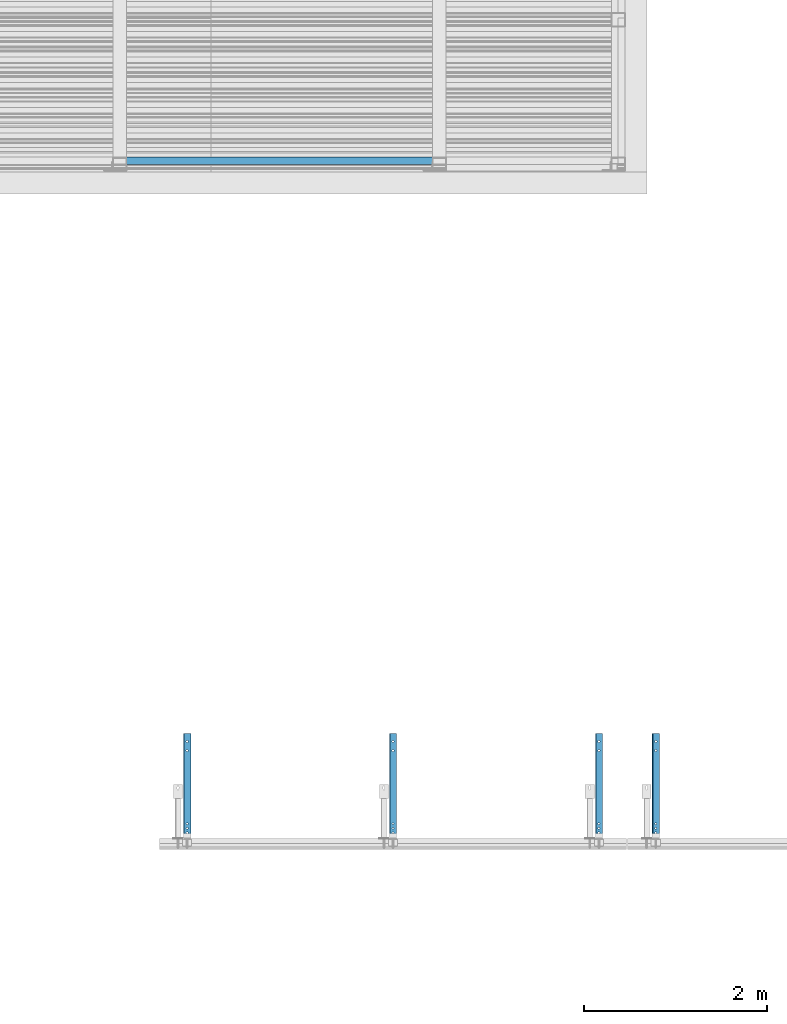
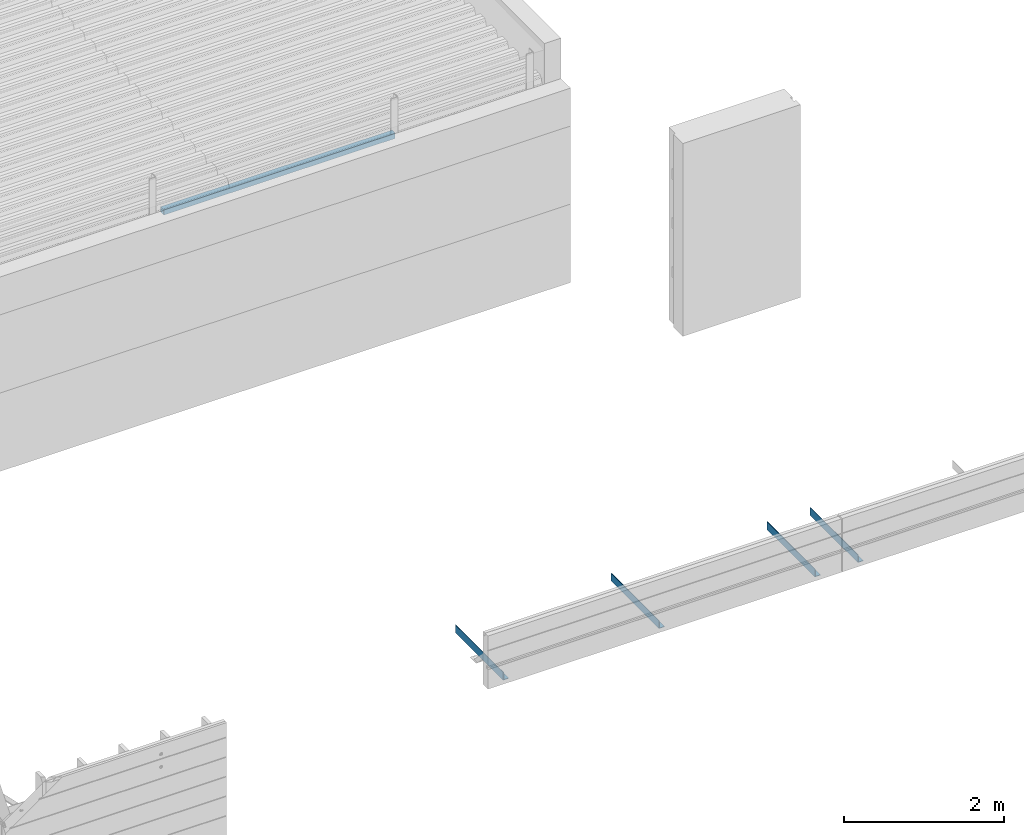
# One storey, part 20 of 153: 5 beams, 5 elements without a shape of their own.
"""IFC2X3 building model written with IfcOpenShell, lengths in millimetres."""

from ifc_helpers import new_model, si_unit, frame, origin_with_axes, place, context, subcontext, project, spatial, faceted_brep, material, type_object, element, aggregate, save


model = new_model("IFC2X3")

# Units and contexts
model_context = context("Model", 3, precision=1e-05, world=origin_with_axes())
body_context = subcontext(model_context, "Body", "Model", "MODEL_VIEW")
ifc_project = project(units=[si_unit("LENGTHUNIT", "METRE", prefix="MILLI"), si_unit("AREAUNIT", "SQUARE_METRE"), si_unit("VOLUMEUNIT", "CUBIC_METRE"), si_unit("MASSUNIT", "GRAM", prefix="KILO"), si_unit("TIMEUNIT", "SECOND"), si_unit("PLANEANGLEUNIT", "RADIAN"), si_unit("SOLIDANGLEUNIT", "STERADIAN"), si_unit("THERMODYNAMICTEMPERATUREUNIT", "DEGREE_CELSIUS"), si_unit("LUMINOUSINTENSITYUNIT", "LUMEN")], contexts=[model_context])

# Site, building, storey
site_placement = place(None, origin_with_axes())
site = spatial("IfcSite", under=ifc_project, at=site_placement, CompositionType="ELEMENT")
building_placement = place(site_placement, origin_with_axes())
building = spatial("IfcBuilding", under=site, at=building_placement, CompositionType="ELEMENT")
storey_placement = place(building_placement, origin_with_axes())
storey = spatial("IfcBuildingStorey", under=building, at=storey_placement, Name="8", CompositionType="ELEMENT", Elevation=0.0)

# Assembly, beam
assembly_1_placement = place(storey_placement, origin_with_axes())
assembly_1 = element("IfcElementAssembly", 1, at=assembly_1_placement, inside=storey, Name="Steel Assembly", AssemblyPlace="NOTDEFINED", PredefinedType="RIGID_FRAME")
ifc_material_1 = material(Name="STEEL/S355J2")
beam_type_1 = type_object("IfcBeamType", Name="80X80X4", PredefinedType="NOTDEFINED")
beam_1_placement = place(assembly_1_placement, frame((16327.0, 15090.0, 105625.0), z_axis=(0.0, 0.0, 1.0), x_axis=(1.0, 0.0, 0.0)))
beam_1 = element("IfcBeam", 2, at=beam_1_placement, type_object=beam_type_1, material=ifc_material_1, ObjectType="80X80X4", context=body_context, shape_type="Brep", body=[
    faceted_brep([(0.0, 36.0, -36.0), (0.0, -36.0, -36.0), (3350.0, -36.0, -36.0), (3350.0, 36.0, -36.0), (0.0, -36.0, 36.0), (3350.0, -36.0, 36.0), (0.0, 36.0, 36.0), (3350.0, 36.0, 36.0), (0.0, 40.0, -40.0), (0.0, 40.0, 40.0), (3350.0, 40.0, 40.0), (3350.0, 40.0, -40.0), (0.0, -40.0, 40.0), (3350.0, -40.0, 40.0), (0.0, -40.0, -40.0), (3350.0, -40.0, -40.0)], [[[0, 1, 2, 3]], [[1, 4, 5, 2]], [[4, 6, 7, 5]], [[6, 0, 3, 7]], [[8, 9, 10, 11]], [[9, 12, 13, 10]], [[12, 14, 15, 13]], [[14, 8, 11, 15]], [[13, 15, 11, 10], [5, 7, 3, 2]], [[14, 12, 9, 8], [6, 4, 1, 0]]]),
])
aggregate(assembly_1, [beam_1])

assembly_2_placement = place(storey_placement, origin_with_axes())
assembly_2 = element("IfcElementAssembly", 3, at=assembly_2_placement, inside=storey, Name="Steel Assembly", AssemblyPlace="NOTDEFINED", PredefinedType="RIGID_FRAME")
ifc_material_2 = material(Name="STEEL/S235J2")
beam_type_2 = type_object("IfcBeamType", PredefinedType="NOTDEFINED")
beam_2_placement = place(assembly_2_placement, frame((16990.0, 7620.0, 102815.0), z_axis=(0.0, 0.0, 1.0), x_axis=(0.0, 1.0, 0.0)))
beam_2 = element("IfcBeam", 4, at=beam_2_placement, type_object=beam_type_2, material=ifc_material_2, context=body_context, shape_type="Brep", body=[
    faceted_brep([(152.928932188135, -7.07106781186485, -52.0), (152.928932188135, -7.07106781186485, -60.0), (150.0, 0.0, -60.0), (150.0, 0.0, -52.0), (152.928932188135, 7.07106781186485, -60.0), (152.928932188135, 7.07106781186485, -52.0), (160.0, 10.0, -60.0), (160.0, 10.0, -52.0), (167.071067811865, 7.07106781186485, -60.0), (167.071067811865, 7.07106781186485, -52.0), (170.0, 0.0, -60.0), (170.0, 0.0, -52.0), (167.071067811865, -7.07106781186485, -60.0), (167.071067811865, -7.07106781186485, -52.0), (160.0, -10.0, -60.0), (160.0, -10.0, -52.0), (0.0, -40.0, -52.0), (0.0, -40.0, -60.0), (1200.0, -40.0, -60.0), (1200.0, -40.0, -52.0), (0.0, 32.0, -52.0), (0.0, 32.0, 60.0), (0.0, 40.0, 60.0), (0.0, 40.0, -60.0), (1200.0, 32.0, -52.0), (1200.0, 32.0, 60.0), (1200.0, 40.0, 60.0), (1200.0, 40.0, -60.0), (1115.75, -9.95929214352145, -52.0), (1115.75, -9.95929214352145, -60.0), (1110.0, -11.5, -60.0), (1110.0, -11.5, -52.0), (1119.95929214352, -5.75, -52.0), (1119.95929214352, -5.75, -60.0), (1121.5, 0.0, -52.0), (1121.5, 0.0, -60.0), (1119.95929214352, 5.75, -52.0), (1119.95929214352, 5.75, -60.0), (1115.75, 9.95929214352145, -52.0), (1115.75, 9.95929214352145, -60.0), (1110.0, 11.5, -52.0), (1110.0, 11.5, -60.0), (1104.25, 9.95929214352145, -52.0), (1104.25, 9.95929214352145, -60.0), (1100.04070785648, 5.75, -52.0), (1100.04070785648, 5.75, -60.0), (1098.5, 0.0, -52.0), (1098.5, 0.0, -60.0), (1100.04070785648, -5.75, -52.0), (1100.04070785648, -5.75, -60.0), (1104.25, -9.95929214352145, -52.0), (1104.25, -9.95929214352145, -60.0), (1015.75, -9.95929214352145, -52.0), (1015.75, -9.95929214352145, -60.0), (1010.0, -11.5, -60.0), (1010.0, -11.5, -52.0), (1019.95929214352, -5.75, -52.0), (1019.95929214352, -5.75, -60.0), (1021.5, 0.0, -52.0), (1021.5, 0.0, -60.0), (1019.95929214352, 5.75, -52.0), (1019.95929214352, 5.75, -60.0), (1015.75, 9.95929214352145, -52.0), (1015.75, 9.95929214352145, -60.0), (1010.0, 11.5, -52.0), (1010.0, 11.5, -60.0), (1004.25, 9.95929214352145, -52.0), (1004.25, 9.95929214352145, -60.0), (1000.04070785648, 5.75, -52.0), (1000.04070785648, 5.75, -60.0), (998.5, 0.0, -52.0), (998.5, 0.0, -60.0), (1000.04070785648, -5.75, -52.0), (1000.04070785648, -5.75, -60.0), (1004.25, -9.95929214352145, -52.0), (1004.25, -9.95929214352145, -60.0), (117.071067811865, -7.07106781186485, -52.0), (117.071067811865, -7.07106781186485, -60.0), (110.0, -10.0, -60.0), (110.0, -10.0, -52.0), (120.0, 0.0, -52.0), (120.0, 0.0, -60.0), (117.071067811865, 7.07106781186485, -52.0), (117.071067811865, 7.07106781186485, -60.0), (110.0, 10.0, -52.0), (110.0, 10.0, -60.0), (102.928932188135, 7.07106781186485, -52.0), (102.928932188135, 7.07106781186485, -60.0), (100.0, 0.0, -52.0), (100.0, 0.0, -60.0), (102.928932188135, -7.07106781186485, -52.0), (102.928932188135, -7.07106781186485, -60.0), (200.0, 0.0, -52.0), (202.928932188135, 7.07106781186485, -52.0), (210.0, 10.0, -52.0), (217.071067811865, 7.07106781186485, -52.0), (220.0, 0.0, -52.0), (217.071067811865, -7.07106781186485, -52.0), (210.0, -10.0, -52.0), (202.928932188135, -7.07106781186485, -52.0), (220.0, 0.0, -60.0), (217.071067811865, -7.07106781186485, -60.0), (217.071067811865, 7.07106781186485, -60.0), (210.0, 10.0, -60.0), (202.928932188135, 7.07106781186485, -60.0), (200.0, 0.0, -60.0), (202.928932188135, -7.07106781186485, -60.0), (210.0, -10.0, -60.0)], [[[0, 1, 2, 3]], [[3, 2, 4, 5]], [[5, 4, 6, 7]], [[7, 6, 8, 9]], [[9, 8, 10, 11]], [[11, 10, 12, 13]], [[13, 12, 14, 15]], [[15, 14, 1, 0]], [[16, 17, 18, 19]], [[17, 16, 20, 21, 22, 23]], [[21, 20, 24, 25]], [[22, 21, 25, 26]], [[23, 22, 26, 27]], [[25, 24, 19, 18, 27, 26]], [[28, 29, 30, 31]], [[32, 33, 29, 28]], [[34, 35, 33, 32]], [[36, 37, 35, 34]], [[38, 39, 37, 36]], [[40, 41, 39, 38]], [[42, 43, 41, 40]], [[44, 45, 43, 42]], [[46, 47, 45, 44]], [[48, 49, 47, 46]], [[50, 51, 49, 48]], [[31, 30, 51, 50]], [[52, 53, 54, 55]], [[56, 57, 53, 52]], [[58, 59, 57, 56]], [[60, 61, 59, 58]], [[62, 63, 61, 60]], [[64, 65, 63, 62]], [[66, 67, 65, 64]], [[68, 69, 67, 66]], [[70, 71, 69, 68]], [[72, 73, 71, 70]], [[74, 75, 73, 72]], [[55, 54, 75, 74]], [[76, 77, 78, 79]], [[80, 81, 77, 76]], [[82, 83, 81, 80]], [[84, 85, 83, 82]], [[86, 87, 85, 84]], [[88, 89, 87, 86]], [[90, 91, 89, 88]], [[79, 78, 91, 90]], [[20, 16, 19, 24], [3, 5, 7, 9, 11, 13, 15, 0], [92, 93, 94, 95, 96, 97, 98, 99], [88, 86, 84, 82, 80, 76, 79, 90], [72, 70, 68, 66, 64, 62, 60, 58, 56, 52, 55, 74], [48, 46, 44, 42, 40, 38, 36, 34, 32, 28, 31, 50]], [[96, 100, 101, 97]], [[95, 102, 100, 96]], [[94, 103, 102, 95]], [[93, 104, 103, 94]], [[92, 105, 104, 93]], [[99, 106, 105, 92]], [[98, 107, 106, 99]], [[97, 101, 107, 98]], [[17, 23, 27, 18], [10, 8, 6, 4, 2, 1, 14, 12], [100, 102, 103, 104, 105, 106, 107, 101], [81, 83, 85, 87, 89, 91, 78, 77], [57, 59, 61, 63, 65, 67, 69, 71, 73, 75, 54, 53], [33, 35, 37, 39, 41, 43, 45, 47, 49, 51, 30, 29]]]),
])
aggregate(assembly_2, [beam_2])

assembly_3_placement = place(storey_placement, origin_with_axes())
assembly_3 = element("IfcElementAssembly", 5, at=assembly_3_placement, inside=storey, Name="Steel Assembly", AssemblyPlace="NOTDEFINED", PredefinedType="RIGID_FRAME")
beam_3_placement = place(assembly_3_placement, frame((22123.0, 7620.0, 102815.0), z_axis=(0.0, 0.0, 1.0), x_axis=(0.0, 1.0, 0.0)))
beam_3 = element("IfcBeam", 6, at=beam_3_placement, type_object=beam_type_2, material=ifc_material_2, context=body_context, shape_type="Brep", body=[
    faceted_brep([(152.928932188135, -7.07106781186485, -52.0), (152.928932188135, -7.07106781186485, -60.0), (150.0, 0.0, -60.0), (150.0, 0.0, -52.0), (152.928932188135, 7.07106781186485, -60.0), (152.928932188135, 7.07106781186485, -52.0), (160.0, 10.0, -60.0), (160.0, 10.0, -52.0), (167.071067811865, 7.07106781186485, -60.0), (167.071067811865, 7.07106781186485, -52.0), (170.0, 0.0, -60.0), (170.0, 0.0, -52.0), (167.071067811865, -7.07106781186485, -60.0), (167.071067811865, -7.07106781186485, -52.0), (160.0, -10.0, -60.0), (160.0, -10.0, -52.0), (0.0, -40.0, -52.0), (0.0, -40.0, -60.0), (1200.0, -40.0, -60.0), (1200.0, -40.0, -52.0), (0.0, 32.0, -52.0), (0.0, 32.0, 60.0), (0.0, 40.0, 60.0), (0.0, 40.0, -60.0), (1200.0, 32.0, -52.0), (1200.0, 32.0, 60.0), (1200.0, 40.0, 60.0), (1200.0, 40.0, -60.0), (1115.75, -9.95929214352145, -52.0), (1115.75, -9.95929214352145, -60.0), (1110.0, -11.5, -60.0), (1110.0, -11.5, -52.0), (1119.95929214352, -5.75, -52.0), (1119.95929214352, -5.75, -60.0), (1121.5, 0.0, -52.0), (1121.5, 0.0, -60.0), (1119.95929214352, 5.75, -52.0), (1119.95929214352, 5.75, -60.0), (1115.75, 9.95929214352145, -52.0), (1115.75, 9.95929214352145, -60.0), (1110.0, 11.5, -52.0), (1110.0, 11.5, -60.0), (1104.25, 9.95929214352145, -52.0), (1104.25, 9.95929214352145, -60.0), (1100.04070785648, 5.75, -52.0), (1100.04070785648, 5.75, -60.0), (1098.5, 0.0, -52.0), (1098.5, 0.0, -60.0), (1100.04070785648, -5.75, -52.0), (1100.04070785648, -5.75, -60.0), (1104.25, -9.95929214352145, -52.0), (1104.25, -9.95929214352145, -60.0), (1015.75, -9.95929214352145, -52.0), (1015.75, -9.95929214352145, -60.0), (1010.0, -11.5, -60.0), (1010.0, -11.5, -52.0), (1019.95929214352, -5.75, -52.0), (1019.95929214352, -5.75, -60.0), (1021.5, 0.0, -52.0), (1021.5, 0.0, -60.0), (1019.95929214352, 5.75, -52.0), (1019.95929214352, 5.75, -60.0), (1015.75, 9.95929214352145, -52.0), (1015.75, 9.95929214352145, -60.0), (1010.0, 11.5, -52.0), (1010.0, 11.5, -60.0), (1004.25, 9.95929214352145, -52.0), (1004.25, 9.95929214352145, -60.0), (1000.04070785648, 5.75, -52.0), (1000.04070785648, 5.75, -60.0), (998.5, 0.0, -52.0), (998.5, 0.0, -60.0), (1000.04070785648, -5.75, -52.0), (1000.04070785648, -5.75, -60.0), (1004.25, -9.95929214352145, -52.0), (1004.25, -9.95929214352145, -60.0), (117.071067811865, -7.07106781186485, -52.0), (117.071067811865, -7.07106781186485, -60.0), (110.0, -10.0, -60.0), (110.0, -10.0, -52.0), (120.0, 0.0, -52.0), (120.0, 0.0, -60.0), (117.071067811865, 7.07106781186485, -52.0), (117.071067811865, 7.07106781186485, -60.0), (110.0, 10.0, -52.0), (110.0, 10.0, -60.0), (102.928932188135, 7.07106781186485, -52.0), (102.928932188135, 7.07106781186485, -60.0), (100.0, 0.0, -52.0), (100.0, 0.0, -60.0), (102.928932188135, -7.07106781186485, -52.0), (102.928932188135, -7.07106781186485, -60.0), (200.0, 0.0, -52.0), (202.928932188135, 7.07106781186485, -52.0), (210.0, 10.0, -52.0), (217.071067811865, 7.07106781186485, -52.0), (220.0, 0.0, -52.0), (217.071067811865, -7.07106781186485, -52.0), (210.0, -10.0, -52.0), (202.928932188135, -7.07106781186485, -52.0), (220.0, 0.0, -60.0), (217.071067811865, -7.07106781186485, -60.0), (217.071067811865, 7.07106781186485, -60.0), (210.0, 10.0, -60.0), (202.928932188135, 7.07106781186485, -60.0), (200.0, 0.0, -60.0), (202.928932188135, -7.07106781186485, -60.0), (210.0, -10.0, -60.0)], [[[0, 1, 2, 3]], [[3, 2, 4, 5]], [[5, 4, 6, 7]], [[7, 6, 8, 9]], [[9, 8, 10, 11]], [[11, 10, 12, 13]], [[13, 12, 14, 15]], [[15, 14, 1, 0]], [[16, 17, 18, 19]], [[17, 16, 20, 21, 22, 23]], [[21, 20, 24, 25]], [[22, 21, 25, 26]], [[23, 22, 26, 27]], [[25, 24, 19, 18, 27, 26]], [[28, 29, 30, 31]], [[32, 33, 29, 28]], [[34, 35, 33, 32]], [[36, 37, 35, 34]], [[38, 39, 37, 36]], [[40, 41, 39, 38]], [[42, 43, 41, 40]], [[44, 45, 43, 42]], [[46, 47, 45, 44]], [[48, 49, 47, 46]], [[50, 51, 49, 48]], [[31, 30, 51, 50]], [[52, 53, 54, 55]], [[56, 57, 53, 52]], [[58, 59, 57, 56]], [[60, 61, 59, 58]], [[62, 63, 61, 60]], [[64, 65, 63, 62]], [[66, 67, 65, 64]], [[68, 69, 67, 66]], [[70, 71, 69, 68]], [[72, 73, 71, 70]], [[74, 75, 73, 72]], [[55, 54, 75, 74]], [[76, 77, 78, 79]], [[80, 81, 77, 76]], [[82, 83, 81, 80]], [[84, 85, 83, 82]], [[86, 87, 85, 84]], [[88, 89, 87, 86]], [[90, 91, 89, 88]], [[79, 78, 91, 90]], [[20, 16, 19, 24], [3, 5, 7, 9, 11, 13, 15, 0], [92, 93, 94, 95, 96, 97, 98, 99], [88, 86, 84, 82, 80, 76, 79, 90], [72, 70, 68, 66, 64, 62, 60, 58, 56, 52, 55, 74], [48, 46, 44, 42, 40, 38, 36, 34, 32, 28, 31, 50]], [[96, 100, 101, 97]], [[95, 102, 100, 96]], [[94, 103, 102, 95]], [[93, 104, 103, 94]], [[92, 105, 104, 93]], [[99, 106, 105, 92]], [[98, 107, 106, 99]], [[97, 101, 107, 98]], [[17, 23, 27, 18], [10, 8, 6, 4, 2, 1, 14, 12], [100, 102, 103, 104, 105, 106, 107, 101], [81, 83, 85, 87, 89, 91, 78, 77], [57, 59, 61, 63, 65, 67, 69, 71, 73, 75, 54, 53], [33, 35, 37, 39, 41, 43, 45, 47, 49, 51, 30, 29]]]),
])
aggregate(assembly_3, [beam_3])

assembly_4_placement = place(storey_placement, origin_with_axes())
assembly_4 = element("IfcElementAssembly", 7, at=assembly_4_placement, inside=storey, Name="Steel Assembly", AssemblyPlace="NOTDEFINED", PredefinedType="RIGID_FRAME")
beam_4_placement = place(assembly_4_placement, frame((19245.0, 7620.0, 102815.0), z_axis=(0.0, 0.0, 1.0), x_axis=(0.0, 1.0, 0.0)))
beam_4 = element("IfcBeam", 8, at=beam_4_placement, type_object=beam_type_2, material=ifc_material_2, context=body_context, shape_type="Brep", body=[
    faceted_brep([(152.928932188135, -7.07106781186485, -52.0), (152.928932188135, -7.07106781186485, -60.0), (150.0, 0.0, -60.0), (150.0, 0.0, -52.0), (152.928932188135, 7.07106781186485, -60.0), (152.928932188135, 7.07106781186485, -52.0), (160.0, 10.0, -60.0), (160.0, 10.0, -52.0), (167.071067811865, 7.07106781186485, -60.0), (167.071067811865, 7.07106781186485, -52.0), (170.0, 0.0, -60.0), (170.0, 0.0, -52.0), (167.071067811865, -7.07106781186485, -60.0), (167.071067811865, -7.07106781186485, -52.0), (160.0, -10.0, -60.0), (160.0, -10.0, -52.0), (0.0, -40.0, -52.0), (0.0, -40.0, -60.0), (1200.0, -40.0, -60.0), (1200.0, -40.0, -52.0), (0.0, 32.0, -52.0), (0.0, 32.0, 60.0), (0.0, 40.0, 60.0), (0.0, 40.0, -60.0), (1200.0, 32.0, -52.0), (1200.0, 32.0, 60.0), (1200.0, 40.0, 60.0), (1200.0, 40.0, -60.0), (1115.75, -9.95929214352145, -52.0), (1115.75, -9.95929214352145, -60.0), (1110.0, -11.5, -60.0), (1110.0, -11.5, -52.0), (1119.95929214352, -5.75, -52.0), (1119.95929214352, -5.75, -60.0), (1121.5, 0.0, -52.0), (1121.5, 0.0, -60.0), (1119.95929214352, 5.75, -52.0), (1119.95929214352, 5.75, -60.0), (1115.75, 9.95929214352145, -52.0), (1115.75, 9.95929214352145, -60.0), (1110.0, 11.5, -52.0), (1110.0, 11.5, -60.0), (1104.25, 9.95929214352145, -52.0), (1104.25, 9.95929214352145, -60.0), (1100.04070785648, 5.75, -52.0), (1100.04070785648, 5.75, -60.0), (1098.5, 0.0, -52.0), (1098.5, 0.0, -60.0), (1100.04070785648, -5.75, -52.0), (1100.04070785648, -5.75, -60.0), (1104.25, -9.95929214352145, -52.0), (1104.25, -9.95929214352145, -60.0), (1015.75, -9.95929214352145, -52.0), (1015.75, -9.95929214352145, -60.0), (1010.0, -11.5, -60.0), (1010.0, -11.5, -52.0), (1019.95929214352, -5.75, -52.0), (1019.95929214352, -5.75, -60.0), (1021.5, 0.0, -52.0), (1021.5, 0.0, -60.0), (1019.95929214352, 5.75, -52.0), (1019.95929214352, 5.75, -60.0), (1015.75, 9.95929214352145, -52.0), (1015.75, 9.95929214352145, -60.0), (1010.0, 11.5, -52.0), (1010.0, 11.5, -60.0), (1004.25, 9.95929214352145, -52.0), (1004.25, 9.95929214352145, -60.0), (1000.04070785648, 5.75, -52.0), (1000.04070785648, 5.75, -60.0), (998.5, 0.0, -52.0), (998.5, 0.0, -60.0), (1000.04070785648, -5.75, -52.0), (1000.04070785648, -5.75, -60.0), (1004.25, -9.95929214352145, -52.0), (1004.25, -9.95929214352145, -60.0), (117.071067811865, -7.07106781186485, -52.0), (117.071067811865, -7.07106781186485, -60.0), (110.0, -10.0, -60.0), (110.0, -10.0, -52.0), (120.0, 0.0, -52.0), (120.0, 0.0, -60.0), (117.071067811865, 7.07106781186485, -52.0), (117.071067811865, 7.07106781186485, -60.0), (110.0, 10.0, -52.0), (110.0, 10.0, -60.0), (102.928932188135, 7.07106781186485, -52.0), (102.928932188135, 7.07106781186485, -60.0), (100.0, 0.0, -52.0), (100.0, 0.0, -60.0), (102.928932188135, -7.07106781186485, -52.0), (102.928932188135, -7.07106781186485, -60.0), (200.0, 0.0, -52.0), (202.928932188135, 7.07106781186485, -52.0), (210.0, 10.0, -52.0), (217.071067811865, 7.07106781186485, -52.0), (220.0, 0.0, -52.0), (217.071067811865, -7.07106781186485, -52.0), (210.0, -10.0, -52.0), (202.928932188135, -7.07106781186485, -52.0), (220.0, 0.0, -60.0), (217.071067811865, -7.07106781186485, -60.0), (217.071067811865, 7.07106781186485, -60.0), (210.0, 10.0, -60.0), (202.928932188135, 7.07106781186485, -60.0), (200.0, 0.0, -60.0), (202.928932188135, -7.07106781186485, -60.0), (210.0, -10.0, -60.0)], [[[0, 1, 2, 3]], [[3, 2, 4, 5]], [[5, 4, 6, 7]], [[7, 6, 8, 9]], [[9, 8, 10, 11]], [[11, 10, 12, 13]], [[13, 12, 14, 15]], [[15, 14, 1, 0]], [[16, 17, 18, 19]], [[17, 16, 20, 21, 22, 23]], [[21, 20, 24, 25]], [[22, 21, 25, 26]], [[23, 22, 26, 27]], [[25, 24, 19, 18, 27, 26]], [[28, 29, 30, 31]], [[32, 33, 29, 28]], [[34, 35, 33, 32]], [[36, 37, 35, 34]], [[38, 39, 37, 36]], [[40, 41, 39, 38]], [[42, 43, 41, 40]], [[44, 45, 43, 42]], [[46, 47, 45, 44]], [[48, 49, 47, 46]], [[50, 51, 49, 48]], [[31, 30, 51, 50]], [[52, 53, 54, 55]], [[56, 57, 53, 52]], [[58, 59, 57, 56]], [[60, 61, 59, 58]], [[62, 63, 61, 60]], [[64, 65, 63, 62]], [[66, 67, 65, 64]], [[68, 69, 67, 66]], [[70, 71, 69, 68]], [[72, 73, 71, 70]], [[74, 75, 73, 72]], [[55, 54, 75, 74]], [[76, 77, 78, 79]], [[80, 81, 77, 76]], [[82, 83, 81, 80]], [[84, 85, 83, 82]], [[86, 87, 85, 84]], [[88, 89, 87, 86]], [[90, 91, 89, 88]], [[79, 78, 91, 90]], [[20, 16, 19, 24], [3, 5, 7, 9, 11, 13, 15, 0], [92, 93, 94, 95, 96, 97, 98, 99], [88, 86, 84, 82, 80, 76, 79, 90], [72, 70, 68, 66, 64, 62, 60, 58, 56, 52, 55, 74], [48, 46, 44, 42, 40, 38, 36, 34, 32, 28, 31, 50]], [[96, 100, 101, 97]], [[95, 102, 100, 96]], [[94, 103, 102, 95]], [[93, 104, 103, 94]], [[92, 105, 104, 93]], [[99, 106, 105, 92]], [[98, 107, 106, 99]], [[97, 101, 107, 98]], [[17, 23, 27, 18], [10, 8, 6, 4, 2, 1, 14, 12], [100, 102, 103, 104, 105, 106, 107, 101], [81, 83, 85, 87, 89, 91, 78, 77], [57, 59, 61, 63, 65, 67, 69, 71, 73, 75, 54, 53], [33, 35, 37, 39, 41, 43, 45, 47, 49, 51, 30, 29]]]),
])
aggregate(assembly_4, [beam_4])

assembly_5_placement = place(storey_placement, origin_with_axes())
assembly_5 = element("IfcElementAssembly", 9, at=assembly_5_placement, inside=storey, Name="Steel Assembly", AssemblyPlace="NOTDEFINED", PredefinedType="RIGID_FRAME")
beam_5_placement = place(assembly_5_placement, frame((21500.0, 7620.0, 102815.0), z_axis=(0.0, 0.0, 1.0), x_axis=(0.0, 1.0, 0.0)))
beam_5 = element("IfcBeam", 10, at=beam_5_placement, type_object=beam_type_2, material=ifc_material_2, context=body_context, shape_type="Brep", body=[
    faceted_brep([(152.928932188135, -7.07106781186485, -52.0), (152.928932188135, -7.07106781186485, -60.0), (150.0, 0.0, -60.0), (150.0, 0.0, -52.0), (152.928932188135, 7.07106781186485, -60.0), (152.928932188135, 7.07106781186485, -52.0), (160.0, 10.0, -60.0), (160.0, 10.0, -52.0), (167.071067811865, 7.07106781186485, -60.0), (167.071067811865, 7.07106781186485, -52.0), (170.0, 0.0, -60.0), (170.0, 0.0, -52.0), (167.071067811865, -7.07106781186485, -60.0), (167.071067811865, -7.07106781186485, -52.0), (160.0, -10.0, -60.0), (160.0, -10.0, -52.0), (0.0, -40.0, -52.0), (0.0, -40.0, -60.0), (1200.0, -40.0, -60.0), (1200.0, -40.0, -52.0), (0.0, 32.0, -52.0), (0.0, 32.0, 60.0), (0.0, 40.0, 60.0), (0.0, 40.0, -60.0), (1200.0, 32.0, -52.0), (1200.0, 32.0, 60.0), (1200.0, 40.0, 60.0), (1200.0, 40.0, -60.0), (1115.75, -9.95929214352145, -52.0), (1115.75, -9.95929214352145, -60.0), (1110.0, -11.5, -60.0), (1110.0, -11.5, -52.0), (1119.95929214352, -5.75, -52.0), (1119.95929214352, -5.75, -60.0), (1121.5, 0.0, -52.0), (1121.5, 0.0, -60.0), (1119.95929214352, 5.75, -52.0), (1119.95929214352, 5.75, -60.0), (1115.75, 9.95929214352145, -52.0), (1115.75, 9.95929214352145, -60.0), (1110.0, 11.5, -52.0), (1110.0, 11.5, -60.0), (1104.25, 9.95929214352145, -52.0), (1104.25, 9.95929214352145, -60.0), (1100.04070785648, 5.75, -52.0), (1100.04070785648, 5.75, -60.0), (1098.5, 0.0, -52.0), (1098.5, 0.0, -60.0), (1100.04070785648, -5.75, -52.0), (1100.04070785648, -5.75, -60.0), (1104.25, -9.95929214352145, -52.0), (1104.25, -9.95929214352145, -60.0), (1015.75, -9.95929214352145, -52.0), (1015.75, -9.95929214352145, -60.0), (1010.0, -11.5, -60.0), (1010.0, -11.5, -52.0), (1019.95929214352, -5.75, -52.0), (1019.95929214352, -5.75, -60.0), (1021.5, 0.0, -52.0), (1021.5, 0.0, -60.0), (1019.95929214352, 5.75, -52.0), (1019.95929214352, 5.75, -60.0), (1015.75, 9.95929214352145, -52.0), (1015.75, 9.95929214352145, -60.0), (1010.0, 11.5, -52.0), (1010.0, 11.5, -60.0), (1004.25, 9.95929214352145, -52.0), (1004.25, 9.95929214352145, -60.0), (1000.04070785648, 5.75, -52.0), (1000.04070785648, 5.75, -60.0), (998.5, 0.0, -52.0), (998.5, 0.0, -60.0), (1000.04070785648, -5.75, -52.0), (1000.04070785648, -5.75, -60.0), (1004.25, -9.95929214352145, -52.0), (1004.25, -9.95929214352145, -60.0), (117.071067811865, -7.07106781186485, -52.0), (117.071067811865, -7.07106781186485, -60.0), (110.0, -10.0, -60.0), (110.0, -10.0, -52.0), (120.0, 0.0, -52.0), (120.0, 0.0, -60.0), (117.071067811865, 7.07106781186485, -52.0), (117.071067811865, 7.07106781186485, -60.0), (110.0, 10.0, -52.0), (110.0, 10.0, -60.0), (102.928932188135, 7.07106781186485, -52.0), (102.928932188135, 7.07106781186485, -60.0), (100.0, 0.0, -52.0), (100.0, 0.0, -60.0), (102.928932188135, -7.07106781186485, -52.0), (102.928932188135, -7.07106781186485, -60.0), (200.0, 0.0, -52.0), (202.928932188135, 7.07106781186485, -52.0), (210.0, 10.0, -52.0), (217.071067811865, 7.07106781186485, -52.0), (220.0, 0.0, -52.0), (217.071067811865, -7.07106781186485, -52.0), (210.0, -10.0, -52.0), (202.928932188135, -7.07106781186485, -52.0), (220.0, 0.0, -60.0), (217.071067811865, -7.07106781186485, -60.0), (217.071067811865, 7.07106781186485, -60.0), (210.0, 10.0, -60.0), (202.928932188135, 7.07106781186485, -60.0), (200.0, 0.0, -60.0), (202.928932188135, -7.07106781186485, -60.0), (210.0, -10.0, -60.0)], [[[0, 1, 2, 3]], [[3, 2, 4, 5]], [[5, 4, 6, 7]], [[7, 6, 8, 9]], [[9, 8, 10, 11]], [[11, 10, 12, 13]], [[13, 12, 14, 15]], [[15, 14, 1, 0]], [[16, 17, 18, 19]], [[17, 16, 20, 21, 22, 23]], [[21, 20, 24, 25]], [[22, 21, 25, 26]], [[23, 22, 26, 27]], [[25, 24, 19, 18, 27, 26]], [[28, 29, 30, 31]], [[32, 33, 29, 28]], [[34, 35, 33, 32]], [[36, 37, 35, 34]], [[38, 39, 37, 36]], [[40, 41, 39, 38]], [[42, 43, 41, 40]], [[44, 45, 43, 42]], [[46, 47, 45, 44]], [[48, 49, 47, 46]], [[50, 51, 49, 48]], [[31, 30, 51, 50]], [[52, 53, 54, 55]], [[56, 57, 53, 52]], [[58, 59, 57, 56]], [[60, 61, 59, 58]], [[62, 63, 61, 60]], [[64, 65, 63, 62]], [[66, 67, 65, 64]], [[68, 69, 67, 66]], [[70, 71, 69, 68]], [[72, 73, 71, 70]], [[74, 75, 73, 72]], [[55, 54, 75, 74]], [[76, 77, 78, 79]], [[80, 81, 77, 76]], [[82, 83, 81, 80]], [[84, 85, 83, 82]], [[86, 87, 85, 84]], [[88, 89, 87, 86]], [[90, 91, 89, 88]], [[79, 78, 91, 90]], [[20, 16, 19, 24], [3, 5, 7, 9, 11, 13, 15, 0], [92, 93, 94, 95, 96, 97, 98, 99], [88, 86, 84, 82, 80, 76, 79, 90], [72, 70, 68, 66, 64, 62, 60, 58, 56, 52, 55, 74], [48, 46, 44, 42, 40, 38, 36, 34, 32, 28, 31, 50]], [[96, 100, 101, 97]], [[95, 102, 100, 96]], [[94, 103, 102, 95]], [[93, 104, 103, 94]], [[92, 105, 104, 93]], [[99, 106, 105, 92]], [[98, 107, 106, 99]], [[97, 101, 107, 98]], [[17, 23, 27, 18], [10, 8, 6, 4, 2, 1, 14, 12], [100, 102, 103, 104, 105, 106, 107, 101], [81, 83, 85, 87, 89, 91, 78, 77], [57, 59, 61, 63, 65, 67, 69, 71, 73, 75, 54, 53], [33, 35, 37, 39, 41, 43, 45, 47, 49, 51, 30, 29]]]),
])
aggregate(assembly_5, [beam_5])

save(model, "model.ifc")
